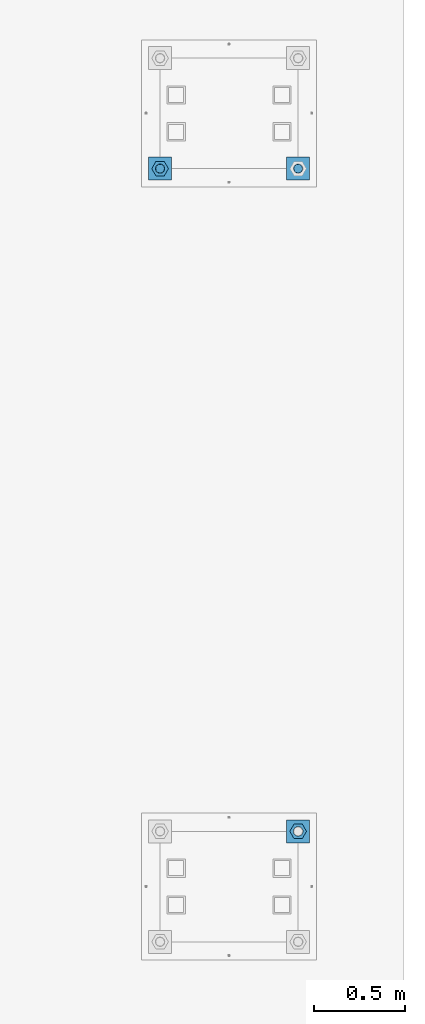
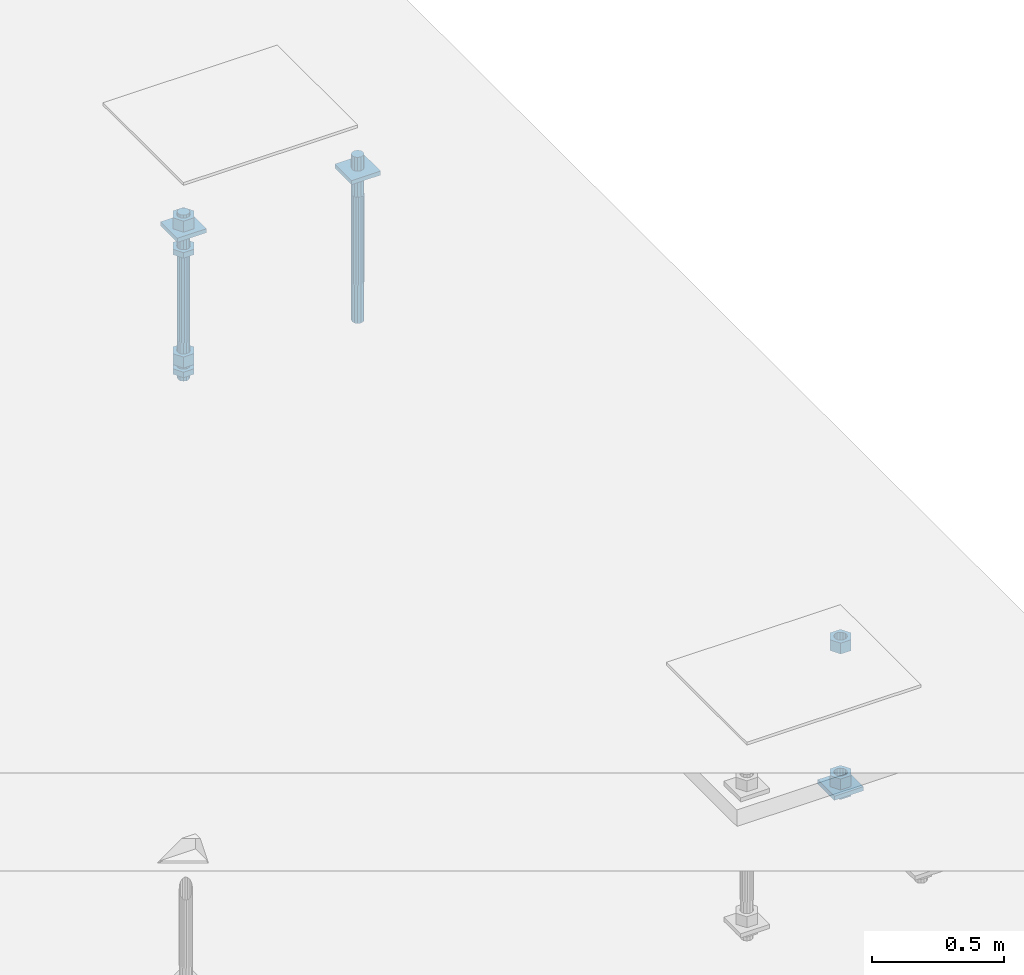
# One storey, part 2652 of 3843: 12 beams, 2 elements without a shape of their own.
"""IFC2X3 building model written with IfcOpenShell, lengths in millimetres."""

from ifc_helpers import new_model, si_unit, frame, origin_with_axes, place, context, subcontext, project, spatial, faceted_brep, material, type_object, element, aggregate, save


model = new_model("IFC2X3")

# Units and contexts
model_context = context("Model", 3, precision=1e-05, world=origin_with_axes())
body_context = subcontext(model_context, "Body", "Model", "MODEL_VIEW")
ifc_project = project(units=[si_unit("LENGTHUNIT", "METRE", prefix="MILLI"), si_unit("AREAUNIT", "SQUARE_METRE"), si_unit("VOLUMEUNIT", "CUBIC_METRE"), si_unit("MASSUNIT", "GRAM", prefix="KILO"), si_unit("TIMEUNIT", "SECOND"), si_unit("PLANEANGLEUNIT", "RADIAN"), si_unit("SOLIDANGLEUNIT", "STERADIAN"), si_unit("THERMODYNAMICTEMPERATUREUNIT", "DEGREE_CELSIUS"), si_unit("LUMINOUSINTENSITYUNIT", "LUMEN")], contexts=[model_context])

# Site, building, storey
site_placement = place(None, origin_with_axes())
site = spatial("IfcSite", under=ifc_project, at=site_placement, CompositionType="ELEMENT")
building_placement = place(site_placement, origin_with_axes())
building = spatial("IfcBuilding", under=site, at=building_placement, Name="Undefined", CompositionType="ELEMENT")
storey_placement = place(building_placement, origin_with_axes())
storey = spatial("IfcBuildingStorey", under=building, at=storey_placement, Name="Undefined", CompositionType="ELEMENT", Elevation=0.0)

# Assembly, beams
assembly_1_placement = place(storey_placement, origin_with_axes())
assembly_1 = element("IfcElementAssembly", 1, at=assembly_1_placement, inside=storey, Name="TEMPLATE", AssemblyPlace="NOTDEFINED", PredefinedType="RIGID_FRAME")
ifc_material_1 = material(Name="STEEL/A572-50")
beam_type_1 = type_object("IfcBeamType", PredefinedType="NOTDEFINED")
beam_1_placement = place(assembly_1_placement, frame((118465.6, 14401.8000015259, 29873.575), z_axis=(1.0, 0.0, 0.0), x_axis=(0.0, 1.0, 0.0)))
beam_1 = element("IfcBeam", 2, at=beam_1_placement, type_object=beam_type_1, material=ifc_material_1, Name="WASHER_PLATE", context=body_context, shape_type="Brep", body=[
    faceted_brep([(0.0, 9.52500000000146, -63.5), (0.0, 9.52500000000146, 63.5), (127.0, 9.52500000000146, 63.5), (127.0, 9.52500000000146, -63.5), (0.0, -9.52500000000146, 63.5), (127.0, -9.52500000000146, 63.5), (0.0, -9.52500000000146, -63.5), (127.0, -9.52500000000146, -63.5)], [[[0, 1, 2, 3]], [[1, 4, 5, 2]], [[4, 6, 7, 5]], [[6, 0, 3, 7]], [[5, 7, 3, 2]], [[6, 4, 1, 0]]]),
])
beam_2_placement = place(assembly_1_placement, frame((119227.6, 14401.8000015259, 29873.575), z_axis=(1.0, 0.0, 0.0), x_axis=(0.0, 1.0, 0.0)))
beam_2 = element("IfcBeam", 3, at=beam_2_placement, type_object=beam_type_1, material=ifc_material_1, Name="WASHER_PLATE", context=body_context, shape_type="Brep", body=[
    faceted_brep([(0.0, 9.52500000000146, -63.5), (0.0, 9.52500000000146, 63.5), (127.0, 9.52500000000146, 63.5), (127.0, 9.52500000000146, -63.5), (0.0, -9.52500000000146, 63.5), (127.0, -9.52500000000146, 63.5), (0.0, -9.52500000000146, -63.5), (127.0, -9.52500000000146, -63.5)], [[[0, 1, 2, 3]], [[1, 4, 5, 2]], [[4, 6, 7, 5]], [[6, 0, 3, 7]], [[5, 7, 3, 2]], [[6, 4, 1, 0]]]),
])

# Assembly, beam
assembly_2_placement = place(storey_placement, origin_with_axes())
assembly_2 = element("IfcElementAssembly", 4, at=assembly_2_placement, inside=storey, Name="TEMPLATE", AssemblyPlace="NOTDEFINED", PredefinedType="RIGID_FRAME")
beam_3_placement = place(assembly_2_placement, frame((119227.6, 10744.2000015259, 29244.925), z_axis=(1.0, 0.0, 0.0), x_axis=(0.0, 1.0, 0.0)))
beam_3 = element("IfcBeam", 5, at=beam_3_placement, type_object=beam_type_1, material=ifc_material_1, Name="WASHER_PLATE", context=body_context, shape_type="Brep", body=[
    faceted_brep([(0.0, 9.52500000000146, -63.5), (0.0, 9.52500000000146, 63.5), (127.0, 9.52500000000146, 63.5), (127.0, 9.52500000000146, -63.5), (0.0, -9.52500000000146, 63.5), (127.0, -9.52500000000146, 63.5), (0.0, -9.52500000000146, -63.5), (127.0, -9.52500000000146, -63.5)], [[[0, 1, 2, 3]], [[1, 4, 5, 2]], [[4, 6, 7, 5]], [[6, 0, 3, 7]], [[5, 7, 3, 2]], [[6, 4, 1, 0]]]),
])

# Beam
ifc_material_2 = material(Name="STEEL/A36")
beam_type_2 = type_object("IfcBeamType", Name="2_HALF_NUT", PredefinedType="NOTDEFINED")
beam_4_placement = place(assembly_1_placement, frame((118465.6, 14465.3000015259, 29787.85), z_axis=(0.0, 1.0, 0.0), x_axis=(0.0, 0.0, -1.0)))
beam_4 = element("IfcBeam", 6, at=beam_4_placement, type_object=beam_type_2, material=ifc_material_2, Name="NUT", ObjectType="2_HALF_NUT", context=body_context, shape_type="Brep", body=[
    faceted_brep([(0.0, -46.0369987487793, 0.0), (0.0, -23.0184993743896, -39.869213104248), (25.4000000000015, -23.0184993743896, -39.869213104248), (25.4000000000015, -46.0369987487793, 0.0), (0.0, 23.0184993743896, -39.869213104248), (25.4000000000015, 23.0184993743896, -39.869213104248), (0.0, 46.0369987487793, 0.0), (25.4000000000015, 46.0369987487793, 0.0), (0.0, 23.0184993743896, 39.869213104248), (25.4000000000015, 23.0184993743896, 39.869213104248), (0.0, -23.0184993743896, 39.869213104248), (25.4000000000015, -23.0184993743896, 39.869213104248), (0.0, 0.0, 26.1940002441406), (0.0, 11.3650617044477, 23.5999013092805), (25.4000000000015, 11.3650617044477, 23.5999013092805), (25.4000000000015, 0.0, 26.1940002441406), (0.0, 20.4791109456419, 16.3316083006721), (25.4000000000015, 20.4791109456419, 16.3316083006721), (0.0, 25.5370200498292, 5.82867859874386), (25.4000000000015, 25.5370200498292, 5.82867859874386), (0.0, 25.5370200498292, -5.82867859874386), (25.4000000000015, 25.5370200498292, -5.82867859874386), (0.0, 20.4791109456419, -16.3316083006721), (25.4000000000015, 20.4791109456419, -16.3316083006721), (0.0, 11.3650617044477, -23.5999013092805), (25.4000000000015, 11.3650617044477, -23.5999013092805), (0.0, 0.0, -26.1940002441406), (25.4000000000015, 0.0, -26.1940002441406), (0.0, -11.3650617044477, -23.5999013092805), (25.4000000000015, -11.3650617044477, -23.5999013092805), (0.0, -20.4791109456419, -16.3316083006721), (25.4000000000015, -20.4791109456419, -16.3316083006721), (0.0, -25.5370200498292, -5.82867859874386), (25.4000000000015, -25.5370200498292, -5.82867859874386), (0.0, -25.5370200498292, 5.82867859874386), (25.4000000000015, -25.5370200498292, 5.82867859874386), (0.0, -20.4791109456419, 16.3316083006721), (25.4000000000015, -20.4791109456419, 16.3316083006721), (0.0, -11.3650617044477, 23.5999013092805), (25.4000000000015, -11.3650617044477, 23.5999013092805)], [[[0, 1, 2, 3]], [[1, 4, 5, 2]], [[4, 6, 7, 5]], [[6, 8, 9, 7]], [[8, 10, 11, 9]], [[10, 0, 3, 11]], [[12, 13, 14, 15]], [[13, 16, 17, 14]], [[16, 18, 19, 17]], [[18, 20, 21, 19]], [[20, 22, 23, 21]], [[22, 24, 25, 23]], [[24, 26, 27, 25]], [[26, 28, 29, 27]], [[28, 30, 31, 29]], [[30, 32, 33, 31]], [[32, 34, 35, 33]], [[34, 36, 37, 35]], [[36, 38, 39, 37]], [[38, 12, 15, 39]], [[5, 7, 9, 11, 3, 2], [17, 19, 21, 23, 25, 27, 29, 31, 33, 35, 37, 39, 15, 14]], [[10, 8, 6, 4, 1, 0], [38, 36, 34, 32, 30, 28, 26, 24, 22, 20, 18, 16, 13, 12]]]),
])

beam_5_placement = place(assembly_1_placement, frame((118465.6, 14465.3000015259, 29235.4), z_axis=(0.0, 1.0, 0.0), x_axis=(0.0, 0.0, -1.0)))
beam_5 = element("IfcBeam", 7, at=beam_5_placement, type_object=beam_type_2, material=ifc_material_2, Name="NUT", ObjectType="2_HALF_NUT", context=body_context, shape_type="Brep", body=[
    faceted_brep([(0.0, -46.0369987487793, 0.0), (0.0, -23.0184993743896, -39.869213104248), (25.4000000000015, -23.0184993743896, -39.869213104248), (25.4000000000015, -46.0369987487793, 0.0), (0.0, 23.0184993743896, -39.869213104248), (25.4000000000015, 23.0184993743896, -39.869213104248), (0.0, 46.0369987487793, 0.0), (25.4000000000015, 46.0369987487793, 0.0), (0.0, 23.0184993743896, 39.869213104248), (25.4000000000015, 23.0184993743896, 39.869213104248), (0.0, -23.0184993743896, 39.869213104248), (25.4000000000015, -23.0184993743896, 39.869213104248), (0.0, 0.0, 26.1940002441406), (0.0, 11.3650617044477, 23.5999013092805), (25.4000000000015, 11.3650617044477, 23.5999013092805), (25.4000000000015, 0.0, 26.1940002441406), (0.0, 20.4791109456419, 16.3316083006721), (25.4000000000015, 20.4791109456419, 16.3316083006721), (0.0, 25.5370200498292, 5.82867859874386), (25.4000000000015, 25.5370200498292, 5.82867859874386), (0.0, 25.5370200498292, -5.82867859874386), (25.4000000000015, 25.5370200498292, -5.82867859874386), (0.0, 20.4791109456419, -16.3316083006721), (25.4000000000015, 20.4791109456419, -16.3316083006721), (0.0, 11.3650617044477, -23.5999013092805), (25.4000000000015, 11.3650617044477, -23.5999013092805), (0.0, 0.0, -26.1940002441406), (25.4000000000015, 0.0, -26.1940002441406), (0.0, -11.3650617044477, -23.5999013092805), (25.4000000000015, -11.3650617044477, -23.5999013092805), (0.0, -20.4791109456419, -16.3316083006721), (25.4000000000015, -20.4791109456419, -16.3316083006721), (0.0, -25.5370200498292, -5.82867859874386), (25.4000000000015, -25.5370200498292, -5.82867859874386), (0.0, -25.5370200498292, 5.82867859874386), (25.4000000000015, -25.5370200498292, 5.82867859874386), (0.0, -20.4791109456419, 16.3316083006721), (25.4000000000015, -20.4791109456419, 16.3316083006721), (0.0, -11.3650617044477, 23.5999013092805), (25.4000000000015, -11.3650617044477, 23.5999013092805)], [[[0, 1, 2, 3]], [[1, 4, 5, 2]], [[4, 6, 7, 5]], [[6, 8, 9, 7]], [[8, 10, 11, 9]], [[10, 0, 3, 11]], [[12, 13, 14, 15]], [[13, 16, 17, 14]], [[16, 18, 19, 17]], [[18, 20, 21, 19]], [[20, 22, 23, 21]], [[22, 24, 25, 23]], [[24, 26, 27, 25]], [[26, 28, 29, 27]], [[28, 30, 31, 29]], [[30, 32, 33, 31]], [[32, 34, 35, 33]], [[34, 36, 37, 35]], [[36, 38, 39, 37]], [[38, 12, 15, 39]], [[5, 7, 9, 11, 3, 2], [17, 19, 21, 23, 25, 27, 29, 31, 33, 35, 37, 39, 15, 14]], [[10, 8, 6, 4, 1, 0], [38, 36, 34, 32, 30, 28, 26, 24, 22, 20, 18, 16, 13, 12]]]),
])

beam_6_placement = place(assembly_2_placement, frame((119227.6, 10807.7000015259, 29235.4), z_axis=(0.0, 1.0, 0.0), x_axis=(0.0, 0.0, -1.0)))
beam_6 = element("IfcBeam", 8, at=beam_6_placement, type_object=beam_type_2, material=ifc_material_2, Name="NUT", ObjectType="2_HALF_NUT", context=body_context, shape_type="Brep", body=[
    faceted_brep([(0.0, -46.0369987487793, 0.0), (0.0, -23.0184993743896, -39.869213104248), (25.4000000000015, -23.0184993743896, -39.869213104248), (25.4000000000015, -46.0369987487793, 0.0), (0.0, 23.0184993743896, -39.869213104248), (25.4000000000015, 23.0184993743896, -39.869213104248), (0.0, 46.0369987487793, 0.0), (25.4000000000015, 46.0369987487793, 0.0), (0.0, 23.0184993743896, 39.869213104248), (25.4000000000015, 23.0184993743896, 39.869213104248), (0.0, -23.0184993743896, 39.869213104248), (25.4000000000015, -23.0184993743896, 39.869213104248), (0.0, 0.0, 26.1940002441406), (0.0, 11.3650617044477, 23.5999013092805), (25.4000000000015, 11.3650617044477, 23.5999013092805), (25.4000000000015, 0.0, 26.1940002441406), (0.0, 20.4791109456419, 16.3316083006721), (25.4000000000015, 20.4791109456419, 16.3316083006721), (0.0, 25.5370200498292, 5.82867859874386), (25.4000000000015, 25.5370200498292, 5.82867859874386), (0.0, 25.5370200498292, -5.82867859874386), (25.4000000000015, 25.5370200498292, -5.82867859874386), (0.0, 20.4791109456419, -16.3316083006721), (25.4000000000015, 20.4791109456419, -16.3316083006721), (0.0, 11.3650617044477, -23.5999013092805), (25.4000000000015, 11.3650617044477, -23.5999013092805), (0.0, 0.0, -26.1940002441406), (25.4000000000015, 0.0, -26.1940002441406), (0.0, -11.3650617044477, -23.5999013092805), (25.4000000000015, -11.3650617044477, -23.5999013092805), (0.0, -20.4791109456419, -16.3316083006721), (25.4000000000015, -20.4791109456419, -16.3316083006721), (0.0, -25.5370200498292, -5.82867859874386), (25.4000000000015, -25.5370200498292, -5.82867859874386), (0.0, -25.5370200498292, 5.82867859874386), (25.4000000000015, -25.5370200498292, 5.82867859874386), (0.0, -20.4791109456419, 16.3316083006721), (25.4000000000015, -20.4791109456419, 16.3316083006721), (0.0, -11.3650617044477, 23.5999013092805), (25.4000000000015, -11.3650617044477, 23.5999013092805)], [[[0, 1, 2, 3]], [[1, 4, 5, 2]], [[4, 6, 7, 5]], [[6, 8, 9, 7]], [[8, 10, 11, 9]], [[10, 0, 3, 11]], [[12, 13, 14, 15]], [[13, 16, 17, 14]], [[16, 18, 19, 17]], [[18, 20, 21, 19]], [[20, 22, 23, 21]], [[22, 24, 25, 23]], [[24, 26, 27, 25]], [[26, 28, 29, 27]], [[28, 30, 31, 29]], [[30, 32, 33, 31]], [[32, 34, 35, 33]], [[34, 36, 37, 35]], [[36, 38, 39, 37]], [[38, 12, 15, 39]], [[5, 7, 9, 11, 3, 2], [17, 19, 21, 23, 25, 27, 29, 31, 33, 35, 37, 39, 15, 14]], [[10, 8, 6, 4, 1, 0], [38, 36, 34, 32, 30, 28, 26, 24, 22, 20, 18, 16, 13, 12]]]),
])

beam_type_3 = type_object("IfcBeamType", Name="2_HEAVY_HEX_NUT", PredefinedType="NOTDEFINED")
beam_7_placement = place(assembly_1_placement, frame((118465.6, 14465.3000015259, 29933.9), z_axis=(0.0, 1.0, 0.0), x_axis=(0.0, 0.0, -1.0)))
beam_7 = element("IfcBeam", 9, at=beam_7_placement, type_object=beam_type_3, material=ifc_material_2, Name="NUT", ObjectType="2_HEAVY_HEX_NUT", context=body_context, shape_type="Brep", body=[
    faceted_brep([(0.0, -46.0369987487793, 0.0), (0.0, -23.0184993743896, -39.869213104248), (50.7999999999993, -23.0184993743896, -39.869213104248), (50.7999999999993, -46.0369987487793, 0.0), (0.0, 23.0184993743896, -39.869213104248), (50.7999999999993, 23.0184993743896, -39.869213104248), (0.0, 46.0369987487793, 0.0), (50.7999999999993, 46.0369987487793, 0.0), (0.0, 23.0184993743896, 39.869213104248), (50.7999999999993, 23.0184993743896, 39.869213104248), (0.0, -23.0184993743896, 39.869213104248), (50.7999999999993, -23.0184993743896, 39.869213104248), (0.0, 0.0, 26.1940002441406), (0.0, 11.3650617044477, 23.5999013092805), (50.7999999999993, 11.3650617044477, 23.5999013092805), (50.7999999999993, 0.0, 26.1940002441406), (0.0, 20.4791109456419, 16.3316083006721), (50.7999999999993, 20.4791109456419, 16.3316083006721), (0.0, 25.5370200498292, 5.82867859874386), (50.7999999999993, 25.5370200498292, 5.82867859874386), (0.0, 25.5370200498292, -5.82867859874386), (50.7999999999993, 25.5370200498292, -5.82867859874386), (0.0, 20.4791109456419, -16.3316083006721), (50.7999999999993, 20.4791109456419, -16.3316083006721), (0.0, 11.3650617044477, -23.5999013092805), (50.7999999999993, 11.3650617044477, -23.5999013092805), (0.0, 0.0, -26.1940002441406), (50.7999999999993, 0.0, -26.1940002441406), (0.0, -11.3650617044477, -23.5999013092805), (50.7999999999993, -11.3650617044477, -23.5999013092805), (0.0, -20.4791109456419, -16.3316083006721), (50.7999999999993, -20.4791109456419, -16.3316083006721), (0.0, -25.5370200498292, -5.82867859874386), (50.7999999999993, -25.5370200498292, -5.82867859874386), (0.0, -25.5370200498292, 5.82867859874386), (50.7999999999993, -25.5370200498292, 5.82867859874386), (0.0, -20.4791109456419, 16.3316083006721), (50.7999999999993, -20.4791109456419, 16.3316083006721), (0.0, -11.3650617044477, 23.5999013092805), (50.7999999999993, -11.3650617044477, 23.5999013092805)], [[[0, 1, 2, 3]], [[1, 4, 5, 2]], [[4, 6, 7, 5]], [[6, 8, 9, 7]], [[8, 10, 11, 9]], [[10, 0, 3, 11]], [[12, 13, 14, 15]], [[13, 16, 17, 14]], [[16, 18, 19, 17]], [[18, 20, 21, 19]], [[20, 22, 23, 21]], [[22, 24, 25, 23]], [[24, 26, 27, 25]], [[26, 28, 29, 27]], [[28, 30, 31, 29]], [[30, 32, 33, 31]], [[32, 34, 35, 33]], [[34, 36, 37, 35]], [[36, 38, 39, 37]], [[38, 12, 15, 39]], [[5, 7, 9, 11, 3, 2], [17, 19, 21, 23, 25, 27, 29, 31, 33, 35, 37, 39, 15, 14]], [[10, 8, 6, 4, 1, 0], [38, 36, 34, 32, 30, 28, 26, 24, 22, 20, 18, 16, 13, 12]]]),
])

beam_8_placement = place(assembly_1_placement, frame((118465.6, 14465.3000015259, 29305.25), z_axis=(0.0, 1.0, 0.0), x_axis=(0.0, 0.0, -1.0)))
beam_8 = element("IfcBeam", 10, at=beam_8_placement, type_object=beam_type_3, material=ifc_material_2, Name="NUT", ObjectType="2_HEAVY_HEX_NUT", context=body_context, shape_type="Brep", body=[
    faceted_brep([(0.0, -46.0369987487793, 0.0), (0.0, -23.0184993743896, -39.869213104248), (50.7999999999993, -23.0184993743896, -39.869213104248), (50.7999999999993, -46.0369987487793, 0.0), (0.0, 23.0184993743896, -39.869213104248), (50.7999999999993, 23.0184993743896, -39.869213104248), (0.0, 46.0369987487793, 0.0), (50.7999999999993, 46.0369987487793, 0.0), (0.0, 23.0184993743896, 39.869213104248), (50.7999999999993, 23.0184993743896, 39.869213104248), (0.0, -23.0184993743896, 39.869213104248), (50.7999999999993, -23.0184993743896, 39.869213104248), (0.0, 0.0, 26.1940002441406), (0.0, 11.3650617044477, 23.5999013092805), (50.7999999999993, 11.3650617044477, 23.5999013092805), (50.7999999999993, 0.0, 26.1940002441406), (0.0, 20.4791109456419, 16.3316083006721), (50.7999999999993, 20.4791109456419, 16.3316083006721), (0.0, 25.5370200498292, 5.82867859874386), (50.7999999999993, 25.5370200498292, 5.82867859874386), (0.0, 25.5370200498292, -5.82867859874386), (50.7999999999993, 25.5370200498292, -5.82867859874386), (0.0, 20.4791109456419, -16.3316083006721), (50.7999999999993, 20.4791109456419, -16.3316083006721), (0.0, 11.3650617044477, -23.5999013092805), (50.7999999999993, 11.3650617044477, -23.5999013092805), (0.0, 0.0, -26.1940002441406), (50.7999999999993, 0.0, -26.1940002441406), (0.0, -11.3650617044477, -23.5999013092805), (50.7999999999993, -11.3650617044477, -23.5999013092805), (0.0, -20.4791109456419, -16.3316083006721), (50.7999999999993, -20.4791109456419, -16.3316083006721), (0.0, -25.5370200498292, -5.82867859874386), (50.7999999999993, -25.5370200498292, -5.82867859874386), (0.0, -25.5370200498292, 5.82867859874386), (50.7999999999993, -25.5370200498292, 5.82867859874386), (0.0, -20.4791109456419, 16.3316083006721), (50.7999999999993, -20.4791109456419, 16.3316083006721), (0.0, -11.3650617044477, 23.5999013092805), (50.7999999999993, -11.3650617044477, 23.5999013092805)], [[[0, 1, 2, 3]], [[1, 4, 5, 2]], [[4, 6, 7, 5]], [[6, 8, 9, 7]], [[8, 10, 11, 9]], [[10, 0, 3, 11]], [[12, 13, 14, 15]], [[13, 16, 17, 14]], [[16, 18, 19, 17]], [[18, 20, 21, 19]], [[20, 22, 23, 21]], [[22, 24, 25, 23]], [[24, 26, 27, 25]], [[26, 28, 29, 27]], [[28, 30, 31, 29]], [[30, 32, 33, 31]], [[32, 34, 35, 33]], [[34, 36, 37, 35]], [[36, 38, 39, 37]], [[38, 12, 15, 39]], [[5, 7, 9, 11, 3, 2], [17, 19, 21, 23, 25, 27, 29, 31, 33, 35, 37, 39, 15, 14]], [[10, 8, 6, 4, 1, 0], [38, 36, 34, 32, 30, 28, 26, 24, 22, 20, 18, 16, 13, 12]]]),
])

beam_9_placement = place(assembly_2_placement, frame((119227.6, 10807.7000015259, 29933.9), z_axis=(0.0, 1.0, 0.0), x_axis=(0.0, 0.0, -1.0)))
beam_9 = element("IfcBeam", 11, at=beam_9_placement, type_object=beam_type_3, material=ifc_material_2, Name="NUT", ObjectType="2_HEAVY_HEX_NUT", context=body_context, shape_type="Brep", body=[
    faceted_brep([(0.0, -46.0369987487793, 0.0), (0.0, -23.0184993743896, -39.869213104248), (50.7999999999993, -23.0184993743896, -39.869213104248), (50.7999999999993, -46.0369987487793, 0.0), (0.0, 23.0184993743896, -39.869213104248), (50.7999999999993, 23.0184993743896, -39.869213104248), (0.0, 46.0369987487793, 0.0), (50.7999999999993, 46.0369987487793, 0.0), (0.0, 23.0184993743896, 39.869213104248), (50.7999999999993, 23.0184993743896, 39.869213104248), (0.0, -23.0184993743896, 39.869213104248), (50.7999999999993, -23.0184993743896, 39.869213104248), (0.0, 0.0, 26.1940002441406), (0.0, 11.3650617044477, 23.5999013092805), (50.7999999999993, 11.3650617044477, 23.5999013092805), (50.7999999999993, 0.0, 26.1940002441406), (0.0, 20.4791109456419, 16.3316083006721), (50.7999999999993, 20.4791109456419, 16.3316083006721), (0.0, 25.5370200498292, 5.82867859874386), (50.7999999999993, 25.5370200498292, 5.82867859874386), (0.0, 25.5370200498292, -5.82867859874386), (50.7999999999993, 25.5370200498292, -5.82867859874386), (0.0, 20.4791109456419, -16.3316083006721), (50.7999999999993, 20.4791109456419, -16.3316083006721), (0.0, 11.3650617044477, -23.5999013092805), (50.7999999999993, 11.3650617044477, -23.5999013092805), (0.0, 0.0, -26.1940002441406), (50.7999999999993, 0.0, -26.1940002441406), (0.0, -11.3650617044477, -23.5999013092805), (50.7999999999993, -11.3650617044477, -23.5999013092805), (0.0, -20.4791109456419, -16.3316083006721), (50.7999999999993, -20.4791109456419, -16.3316083006721), (0.0, -25.5370200498292, -5.82867859874386), (50.7999999999993, -25.5370200498292, -5.82867859874386), (0.0, -25.5370200498292, 5.82867859874386), (50.7999999999993, -25.5370200498292, 5.82867859874386), (0.0, -20.4791109456419, 16.3316083006721), (50.7999999999993, -20.4791109456419, 16.3316083006721), (0.0, -11.3650617044477, 23.5999013092805), (50.7999999999993, -11.3650617044477, 23.5999013092805)], [[[0, 1, 2, 3]], [[1, 4, 5, 2]], [[4, 6, 7, 5]], [[6, 8, 9, 7]], [[8, 10, 11, 9]], [[10, 0, 3, 11]], [[12, 13, 14, 15]], [[13, 16, 17, 14]], [[16, 18, 19, 17]], [[18, 20, 21, 19]], [[20, 22, 23, 21]], [[22, 24, 25, 23]], [[24, 26, 27, 25]], [[26, 28, 29, 27]], [[28, 30, 31, 29]], [[30, 32, 33, 31]], [[32, 34, 35, 33]], [[34, 36, 37, 35]], [[36, 38, 39, 37]], [[38, 12, 15, 39]], [[5, 7, 9, 11, 3, 2], [17, 19, 21, 23, 25, 27, 29, 31, 33, 35, 37, 39, 15, 14]], [[10, 8, 6, 4, 1, 0], [38, 36, 34, 32, 30, 28, 26, 24, 22, 20, 18, 16, 13, 12]]]),
])

beam_10_placement = place(assembly_2_placement, frame((119227.6, 10807.7000015259, 29305.25), z_axis=(0.0, 1.0, 0.0), x_axis=(0.0, 0.0, -1.0)))
beam_10 = element("IfcBeam", 12, at=beam_10_placement, type_object=beam_type_3, material=ifc_material_2, Name="NUT", ObjectType="2_HEAVY_HEX_NUT", context=body_context, shape_type="Brep", body=[
    faceted_brep([(0.0, -46.0369987487793, 0.0), (0.0, -23.0184993743896, -39.869213104248), (50.7999999999993, -23.0184993743896, -39.869213104248), (50.7999999999993, -46.0369987487793, 0.0), (0.0, 23.0184993743896, -39.869213104248), (50.7999999999993, 23.0184993743896, -39.869213104248), (0.0, 46.0369987487793, 0.0), (50.7999999999993, 46.0369987487793, 0.0), (0.0, 23.0184993743896, 39.869213104248), (50.7999999999993, 23.0184993743896, 39.869213104248), (0.0, -23.0184993743896, 39.869213104248), (50.7999999999993, -23.0184993743896, 39.869213104248), (0.0, 0.0, 26.1940002441406), (0.0, 11.3650617044477, 23.5999013092805), (50.7999999999993, 11.3650617044477, 23.5999013092805), (50.7999999999993, 0.0, 26.1940002441406), (0.0, 20.4791109456419, 16.3316083006721), (50.7999999999993, 20.4791109456419, 16.3316083006721), (0.0, 25.5370200498292, 5.82867859874386), (50.7999999999993, 25.5370200498292, 5.82867859874386), (0.0, 25.5370200498292, -5.82867859874386), (50.7999999999993, 25.5370200498292, -5.82867859874386), (0.0, 20.4791109456419, -16.3316083006721), (50.7999999999993, 20.4791109456419, -16.3316083006721), (0.0, 11.3650617044477, -23.5999013092805), (50.7999999999993, 11.3650617044477, -23.5999013092805), (0.0, 0.0, -26.1940002441406), (50.7999999999993, 0.0, -26.1940002441406), (0.0, -11.3650617044477, -23.5999013092805), (50.7999999999993, -11.3650617044477, -23.5999013092805), (0.0, -20.4791109456419, -16.3316083006721), (50.7999999999993, -20.4791109456419, -16.3316083006721), (0.0, -25.5370200498292, -5.82867859874386), (50.7999999999993, -25.5370200498292, -5.82867859874386), (0.0, -25.5370200498292, 5.82867859874386), (50.7999999999993, -25.5370200498292, 5.82867859874386), (0.0, -20.4791109456419, 16.3316083006721), (50.7999999999993, -20.4791109456419, 16.3316083006721), (0.0, -11.3650617044477, 23.5999013092805), (50.7999999999993, -11.3650617044477, 23.5999013092805)], [[[0, 1, 2, 3]], [[1, 4, 5, 2]], [[4, 6, 7, 5]], [[6, 8, 9, 7]], [[8, 10, 11, 9]], [[10, 0, 3, 11]], [[12, 13, 14, 15]], [[13, 16, 17, 14]], [[16, 18, 19, 17]], [[18, 20, 21, 19]], [[20, 22, 23, 21]], [[22, 24, 25, 23]], [[24, 26, 27, 25]], [[26, 28, 29, 27]], [[28, 30, 31, 29]], [[30, 32, 33, 31]], [[32, 34, 35, 33]], [[34, 36, 37, 35]], [[36, 38, 39, 37]], [[38, 12, 15, 39]], [[5, 7, 9, 11, 3, 2], [17, 19, 21, 23, 25, 27, 29, 31, 33, 35, 37, 39, 15, 14]], [[10, 8, 6, 4, 1, 0], [38, 36, 34, 32, 30, 28, 26, 24, 22, 20, 18, 16, 13, 12]]]),
])

aggregate(assembly_2, [beam_9, beam_10, beam_6, beam_3])

ifc_material_3 = material()
beam_type_4 = type_object("IfcBeamType", PredefinedType="NOTDEFINED")
beam_11_placement = place(assembly_1_placement, frame((118465.600001526, 14465.3, 29762.45), z_axis=(1.0, 0.0, 0.0), x_axis=(0.0, 0.0, -1.0)))
beam_11 = element("IfcBeam", 13, at=beam_11_placement, type_object=beam_type_4, material=ifc_material_3, Name="ANCHOR_ROD", context=body_context, shape_type="Brep", body=[
    faceted_brep([(0.0, -23.4665401257807, -9.72015918207035), (0.0, -17.9605122421344, -17.9605122421417), (406.399999999998, -17.9605122421344, -17.9605122421417), (406.399999999998, -23.4665401257807, -9.72015918207035), (0.0, -9.72015918207762, -23.466540125788), (406.399999999998, -9.72015918207762, -23.466540125788), (0.0, 0.0, -25.4000000000015), (406.399999999998, 0.0, -25.4000000000015), (0.0, 9.72015918207762, -23.466540125788), (406.399999999998, 9.72015918207762, -23.466540125788), (0.0, 17.9605122421344, -17.9605122421417), (406.399999999998, 17.9605122421344, -17.9605122421417), (0.0, 23.4665401257807, -9.72015918207035), (406.399999999998, 23.4665401257807, -9.72015918207035), (0.0, 25.3999996185303, 0.0), (406.399999999998, 25.3999999999942, 0.0), (0.0, 23.4665401257807, 9.72015918207035), (406.399999999998, 23.4665401257807, 9.72015918207035), (0.0, 17.9605122421344, 17.9605122421417), (406.399999999998, 17.9605122421344, 17.9605122421417), (0.0, 9.72015918207762, 23.466540125788), (406.399999999998, 9.72015918207762, 23.466540125788), (0.0, 0.0, 25.4000000000015), (406.399999999998, 0.0, 25.4000000000015), (0.0, -9.72015918207762, 23.466540125788), (406.399999999998, -9.72015918207762, 23.466540125788), (0.0, -17.9605122421344, 17.9605122421417), (406.399999999998, -17.9605122421344, 17.9605122421417), (0.0, -23.4665401257807, 9.72015918207035), (406.399999999998, -23.4665401257807, 9.72015918207035), (0.0, -25.3999996185303, 0.0), (406.399999999998, -25.3999999999942, 0.0), (584.200000000001, -12.2499999999854, -21.2176223927163), (584.200000000001, 1.45519152283669e-11, -24.5), (584.200000000001, 12.2500000000146, -21.2176223927163), (584.200000000001, 21.2176223927381, -12.25), (584.200000000001, 24.5000000000146, 0.0), (584.200000000001, 21.2176223927381, 12.25), (584.200000000001, 12.2500000000146, 21.2176223927163), (584.200000000001, 1.45519152283669e-11, 24.5), (584.200000000001, -12.2499999999854, 21.2176223927163), (584.200000000001, -21.217622392709, 12.25), (584.200000000001, -24.4999999999854, 0.0), (584.200000000001, -21.217622392709, -12.25), (406.399999999998, -24.4999999999854, 0.0), (406.399999999998, -21.217622392709, -12.25), (406.399999999998, -12.2499999999854, -21.2176223927163), (406.399999999998, 1.45519152283669e-11, -24.5), (406.399999999998, 12.2500000000146, -21.2176223927163), (406.399999999998, 21.2176223927381, -12.25), (406.399999999998, 24.5000000000146, 0.0), (406.399999999998, 21.2176223927381, 12.25), (406.399999999998, 12.2500000000146, 21.2176223927163), (406.399999999998, 1.45519152283669e-11, 24.5), (406.399999999998, -12.2499999999854, 21.2176223927163), (406.399999999998, -21.217622392709, 12.25), (0.0, 12.2500000000146, 21.2176223927163), (0.0, 1.45519152283669e-11, 24.5), (0.0, -12.2499999999854, 21.2176223927163), (0.0, -21.217622392709, 12.25), (0.0, -24.4999999999854, 0.0), (0.0, -21.217622392709, -12.25), (0.0, -12.2499999999854, -21.2176223927163), (0.0, 1.45519152283669e-11, -24.5), (0.0, 12.2500000000146, -21.2176223927163), (0.0, 21.2176223927381, -12.25), (0.0, 24.5000000000146, 0.0), (0.0, 21.2176223927381, 12.25), (-184.150000000001, -21.217622392709, 12.25), (-184.150000000001, -12.2499999999854, 21.2176223927163), (-184.150000000001, 1.45519152283669e-11, 24.5), (-184.150000000001, 12.2500000000146, 21.2176223927163), (-184.150000000001, 21.2176223927381, 12.25), (-184.150000000001, 24.5000000000146, 0.0), (-184.150000000001, 21.2176223927381, -12.25), (-184.150000000001, 12.2500000000146, -21.2176223927163), (-184.150000000001, 1.45519152283669e-11, -24.5), (-184.150000000001, -12.2499999999854, -21.2176223927163), (-184.150000000001, -21.217622392709, -12.25), (-184.150000000001, -24.4999999999854, 0.0)], [[[0, 1, 2, 3]], [[1, 4, 5, 2]], [[4, 6, 7, 5]], [[6, 8, 9, 7]], [[8, 10, 11, 9]], [[10, 12, 13, 11]], [[12, 14, 15, 13]], [[14, 16, 17, 15]], [[16, 18, 19, 17]], [[18, 20, 21, 19]], [[20, 22, 23, 21]], [[22, 24, 25, 23]], [[24, 26, 27, 25]], [[26, 28, 29, 27]], [[28, 30, 31, 29]], [[32, 33, 34, 35, 36, 37, 38, 39, 40, 41, 42, 43]], [[43, 42, 44, 45]], [[32, 43, 45, 46]], [[33, 32, 46, 47]], [[34, 33, 47, 48]], [[35, 34, 48, 49]], [[36, 35, 49, 50]], [[37, 36, 50, 51]], [[38, 37, 51, 52]], [[39, 38, 52, 53]], [[40, 39, 53, 54]], [[41, 40, 54, 55]], [[42, 41, 55, 44]], [[2, 5, 7, 9, 11, 13, 15, 17, 19, 21, 23, 25, 27, 29, 31, 3], [54, 53, 52, 51, 50, 49, 48, 47, 46, 45, 44, 55]], [[30, 0, 3, 31]], [[28, 26, 24, 22, 20, 18, 16, 14, 12, 10, 8, 6, 4, 1, 0, 30], [56, 57, 58, 59, 60, 61, 62, 63, 64, 65, 66, 67]], [[68, 69, 70, 71, 72, 73, 74, 75, 76, 77, 78, 79]], [[71, 70, 57, 56]], [[72, 71, 56, 67]], [[73, 72, 67, 66]], [[74, 73, 66, 65]], [[75, 74, 65, 64]], [[76, 75, 64, 63]], [[77, 76, 63, 62]], [[78, 77, 62, 61]], [[79, 78, 61, 60]], [[68, 79, 60, 59]], [[69, 68, 59, 58]], [[70, 69, 58, 57]]]),
])

beam_12_placement = place(assembly_1_placement, frame((119227.600001526, 14465.3, 29762.45), z_axis=(1.0, 0.0, 0.0), x_axis=(0.0, 0.0, -1.0)))
beam_12 = element("IfcBeam", 14, at=beam_12_placement, type_object=beam_type_4, material=ifc_material_3, Name="ANCHOR_ROD", context=body_context, shape_type="Brep", body=[
    faceted_brep([(0.0, -23.4665401257807, -9.72015918207035), (0.0, -17.9605122421344, -17.9605122421417), (406.399999999998, -17.9605122421344, -17.9605122421417), (406.399999999998, -23.4665401257807, -9.72015918207035), (0.0, -9.72015918207762, -23.466540125788), (406.399999999998, -9.72015918207762, -23.466540125788), (0.0, 0.0, -25.4000000000015), (406.399999999998, 0.0, -25.4000000000015), (0.0, 9.72015918207762, -23.466540125788), (406.399999999998, 9.72015918207762, -23.466540125788), (0.0, 17.9605122421344, -17.9605122421417), (406.399999999998, 17.9605122421344, -17.9605122421417), (0.0, 23.4665401257807, -9.72015918207035), (406.399999999998, 23.4665401257807, -9.72015918207035), (0.0, 25.3999996185303, 0.0), (406.399999999998, 25.3999999999942, 0.0), (0.0, 23.4665401257807, 9.72015918207035), (406.399999999998, 23.4665401257807, 9.72015918207035), (0.0, 17.9605122421344, 17.9605122421417), (406.399999999998, 17.9605122421344, 17.9605122421417), (0.0, 9.72015918207762, 23.466540125788), (406.399999999998, 9.72015918207762, 23.466540125788), (0.0, 0.0, 25.4000000000015), (406.399999999998, 0.0, 25.4000000000015), (0.0, -9.72015918207762, 23.466540125788), (406.399999999998, -9.72015918207762, 23.466540125788), (0.0, -17.9605122421344, 17.9605122421417), (406.399999999998, -17.9605122421344, 17.9605122421417), (0.0, -23.4665401257807, 9.72015918207035), (406.399999999998, -23.4665401257807, 9.72015918207035), (0.0, -25.3999996185303, 0.0), (406.399999999998, -25.3999999999942, 0.0), (584.200000000001, -12.2499999999854, -21.2176223927163), (584.200000000001, 1.45519152283669e-11, -24.5), (584.200000000001, 12.2500000000146, -21.2176223927163), (584.200000000001, 21.2176223927381, -12.25), (584.200000000001, 24.5000000000146, 0.0), (584.200000000001, 21.2176223927381, 12.25), (584.200000000001, 12.2500000000146, 21.2176223927163), (584.200000000001, 1.45519152283669e-11, 24.5), (584.200000000001, -12.2499999999854, 21.2176223927163), (584.200000000001, -21.217622392709, 12.25), (584.200000000001, -24.4999999999854, 0.0), (584.200000000001, -21.217622392709, -12.25), (406.399999999998, -24.4999999999854, 0.0), (406.399999999998, -21.217622392709, -12.25), (406.399999999998, -12.2499999999854, -21.2176223927163), (406.399999999998, 1.45519152283669e-11, -24.5), (406.399999999998, 12.2500000000146, -21.2176223927163), (406.399999999998, 21.2176223927381, -12.25), (406.399999999998, 24.5000000000146, 0.0), (406.399999999998, 21.2176223927381, 12.25), (406.399999999998, 12.2500000000146, 21.2176223927163), (406.399999999998, 1.45519152283669e-11, 24.5), (406.399999999998, -12.2499999999854, 21.2176223927163), (406.399999999998, -21.217622392709, 12.25), (0.0, 12.2500000000146, 21.2176223927163), (0.0, 1.45519152283669e-11, 24.5), (0.0, -12.2499999999854, 21.2176223927163), (0.0, -21.217622392709, 12.25), (0.0, -24.4999999999854, 0.0), (0.0, -21.217622392709, -12.25), (0.0, -12.2499999999854, -21.2176223927163), (0.0, 1.45519152283669e-11, -24.5), (0.0, 12.2500000000146, -21.2176223927163), (0.0, 21.2176223927381, -12.25), (0.0, 24.5000000000146, 0.0), (0.0, 21.2176223927381, 12.25), (-184.150000000001, -21.217622392709, 12.25), (-184.150000000001, -12.2499999999854, 21.2176223927163), (-184.150000000001, 1.45519152283669e-11, 24.5), (-184.150000000001, 12.2500000000146, 21.2176223927163), (-184.150000000001, 21.2176223927381, 12.25), (-184.150000000001, 24.5000000000146, 0.0), (-184.150000000001, 21.2176223927381, -12.25), (-184.150000000001, 12.2500000000146, -21.2176223927163), (-184.150000000001, 1.45519152283669e-11, -24.5), (-184.150000000001, -12.2499999999854, -21.2176223927163), (-184.150000000001, -21.217622392709, -12.25), (-184.150000000001, -24.4999999999854, 0.0)], [[[0, 1, 2, 3]], [[1, 4, 5, 2]], [[4, 6, 7, 5]], [[6, 8, 9, 7]], [[8, 10, 11, 9]], [[10, 12, 13, 11]], [[12, 14, 15, 13]], [[14, 16, 17, 15]], [[16, 18, 19, 17]], [[18, 20, 21, 19]], [[20, 22, 23, 21]], [[22, 24, 25, 23]], [[24, 26, 27, 25]], [[26, 28, 29, 27]], [[28, 30, 31, 29]], [[32, 33, 34, 35, 36, 37, 38, 39, 40, 41, 42, 43]], [[43, 42, 44, 45]], [[32, 43, 45, 46]], [[33, 32, 46, 47]], [[34, 33, 47, 48]], [[35, 34, 48, 49]], [[36, 35, 49, 50]], [[37, 36, 50, 51]], [[38, 37, 51, 52]], [[39, 38, 52, 53]], [[40, 39, 53, 54]], [[41, 40, 54, 55]], [[42, 41, 55, 44]], [[2, 5, 7, 9, 11, 13, 15, 17, 19, 21, 23, 25, 27, 29, 31, 3], [54, 53, 52, 51, 50, 49, 48, 47, 46, 45, 44, 55]], [[30, 0, 3, 31]], [[28, 26, 24, 22, 20, 18, 16, 14, 12, 10, 8, 6, 4, 1, 0, 30], [56, 57, 58, 59, 60, 61, 62, 63, 64, 65, 66, 67]], [[68, 69, 70, 71, 72, 73, 74, 75, 76, 77, 78, 79]], [[71, 70, 57, 56]], [[72, 71, 56, 67]], [[73, 72, 67, 66]], [[74, 73, 66, 65]], [[75, 74, 65, 64]], [[76, 75, 64, 63]], [[77, 76, 63, 62]], [[78, 77, 62, 61]], [[79, 78, 61, 60]], [[68, 79, 60, 59]], [[69, 68, 59, 58]], [[70, 69, 58, 57]]]),
])

aggregate(assembly_1, [beam_11, beam_12, beam_1, beam_2, beam_4, beam_7, beam_8, beam_5])

save(model, "model.ifc")
